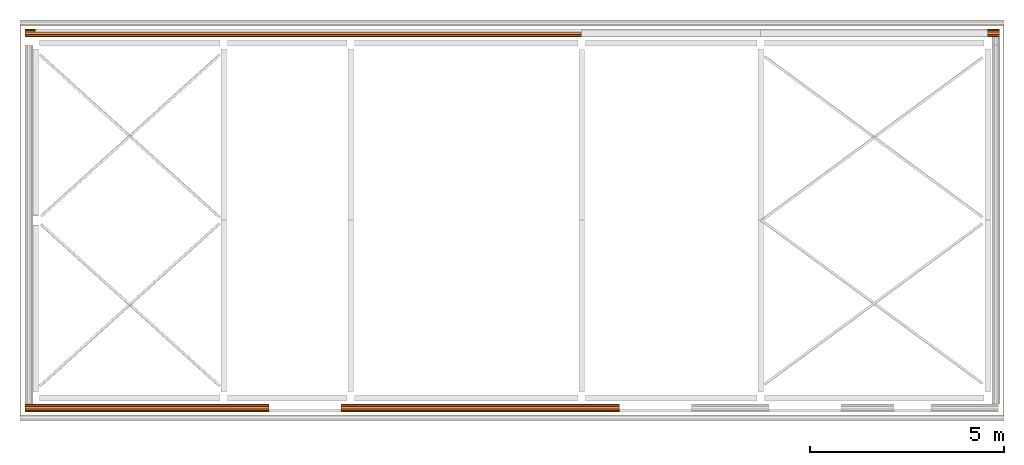
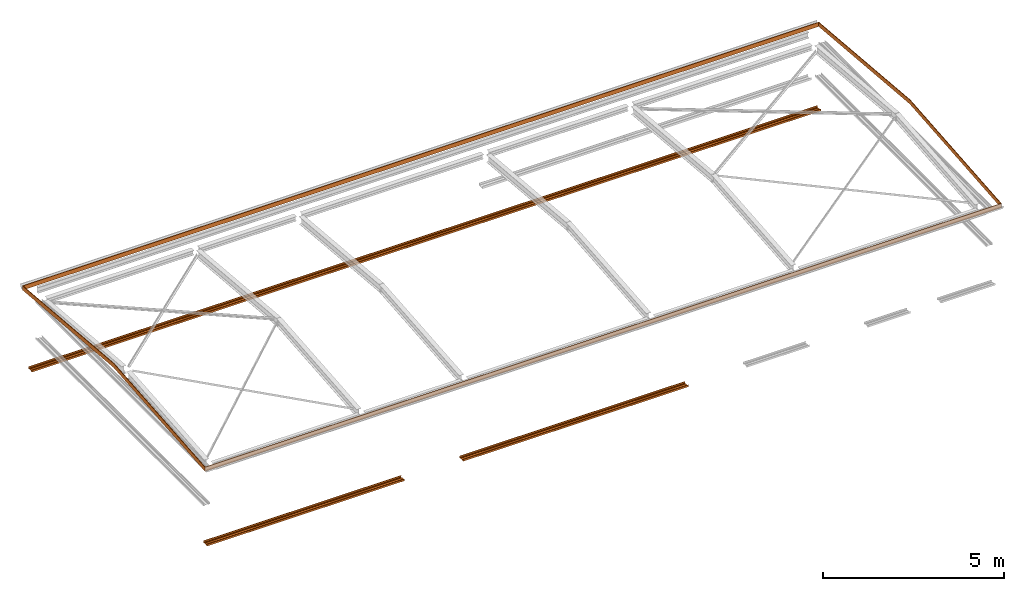
# One storey, part 6 of 8: 4 proxies.
"""IFC2X3 building model written with IfcOpenShell, lengths in millimetres."""

from ifc_helpers import new_model, entity, si_unit, converted_unit, money_unit, direction, frame, origin_with_axes, place, context, subcontext, project, spatial, faceted_brep, material, type_object, element, save


model = new_model("IFC2X3")

# Units and contexts
model_context = context("Model", 3, precision=1e-05, world=origin_with_axes(), true_north=direction((0.0, 1.0)))
body_context = subcontext(model_context, "Body", "Model", "MODEL_VIEW")
ifc_project = project(units=[si_unit("LENGTHUNIT", "METRE", prefix="MILLI"), si_unit("AREAUNIT", "SQUARE_METRE"), si_unit("VOLUMEUNIT", "CUBIC_METRE"), converted_unit("PLANEANGLEUNIT", "DEGREE", entity("IfcPlaneAngleMeasure", 0.0174532925199), si_unit("PLANEANGLEUNIT", "RADIAN"), dimensions=[0, 0, 0, 0, 0, 0, 0]), si_unit("SOLIDANGLEUNIT", "STERADIAN"), money_unit("USD"), converted_unit("TIMEUNIT", "Year", entity("IfcTimeMeasure", 31556926.0), si_unit("TIMEUNIT", "SECOND"), dimensions=[0, 0, 0, 0, 0, 0, 0]), si_unit("MASSUNIT", "GRAM"), si_unit("THERMODYNAMICTEMPERATUREUNIT", "DEGREE_CELSIUS"), si_unit("LUMINOUSINTENSITYUNIT", "LUMEN")], contexts=[model_context])

# Site, building, storey
site_placement = place(None, origin_with_axes())
site = spatial("IfcSite", under=ifc_project, at=site_placement, CompositionType="ELEMENT")
building_placement = place(site_placement, origin_with_axes())
building = spatial("IfcBuilding", under=site, at=building_placement, CompositionType="ELEMENT")
storey_placement = place(building_placement, frame((0.0, 0.0, 74215.0), z_axis=(0.0, 0.0, 1.0), x_axis=(1.0, 0.0, 0.0)))
storey = spatial("IfcBuildingStorey", under=building, at=storey_placement, CompositionType="ELEMENT", Elevation=74215.0)

# Proxies
ifc_material_1 = material(Name="IFC Building Material")
building_element_proxy_type_1 = type_object("IfcBuildingElementProxyType", Name="Model Element 499", PredefinedType="NOTDEFINED")
proxy_1_placement = place(storey_placement, frame((-8525.22088657, -1461.32006319, 111.536956869), z_axis=(0.0, 0.0, 1.0), x_axis=(1.0, 0.0, 0.0)))
element("IfcBuildingElementProxy", 1, at=proxy_1_placement, inside=storey, type_object=building_element_proxy_type_1, material=ifc_material_1, Name="Fascia:Standard", ObjectType="Fascia:Standard", context=body_context, shape_type="Brep", body=[
    faceted_brep([(25333.2504249, 10058.5999698, 140.0), (25352.2504249, 10077.5999698, 140.0), (0.0, 10077.5999698, 140.0), (19.0, 10058.5999698, 140.0), (25352.2504249, 10058.5999698, 140.0), (25352.2504249, 10077.5999698, 0.0), (0.0, 10077.5999698, 0.0), (0.0, 10058.5999698, 140.0), (25333.2504249, 10058.5999698, 0.0), (19.0, 10058.5999698, 0.0), (25333.2504249, 5038.79998489, 579.175591845), (25352.2504249, 5038.79998489, 579.175591845), (25352.2504249, 10052.4874378, 0.0), (0.0, 10052.4874378, 0.0), (0.0, 5038.79998489, 579.175591845), (19.0, 5038.79998489, 579.175591845), (25333.2504249, 10052.4874378, 0.0), (19.0, 10052.4874378, 0.0), (25333.2504249, 19.0, 140.0), (25352.2504249, 19.0, 140.0), (25352.2504249, 5038.79998489, 438.640814589), (25333.2504249, 5038.79998489, 438.640814589), (0.0, 5038.79998489, 438.640814589), (0.0, 19.0, 140.0), (19.0, 19.0, 140.0), (19.0, 5038.79998489, 438.640814589), (25352.2504249, 0.0, 140.0), (25352.2504249, 25.1125320072, 0.0), (25333.2504249, 25.1125320072, 0.0), (0.0, 25.1125320072, 0.0), (0.0, 0.0, 140.0), (19.0, 25.1125320072, 0.0), (25352.2504249, 0.0, 0.0), (25333.2504249, 19.0, 0.0), (0.0, 0.0, 0.0), (19.0, 19.0, 0.0)], [[[0, 1, 2, 3]], [[0, 4, 1]], [[1, 5, 6, 2]], [[3, 2, 7]], [[8, 0, 3, 9]], [[10, 11, 4, 0]], [[4, 12, 5, 1]], [[5, 8, 9, 6]], [[2, 6, 13, 7]], [[3, 7, 14, 15]], [[16, 0, 8]], [[9, 3, 17]], [[18, 19, 11, 10]], [[11, 20, 12, 4]], [[21, 10, 0, 16]], [[12, 16, 8, 5]], [[6, 9, 17, 13]], [[7, 13, 22, 14]], [[15, 14, 23, 24]], [[17, 3, 15, 25]], [[18, 26, 19]], [[19, 27, 20, 11]], [[28, 18, 10, 21]], [[20, 21, 16, 12]], [[13, 17, 25, 22]], [[14, 22, 29, 23]], [[24, 23, 30]], [[25, 15, 24, 31]], [[24, 30, 26, 18]], [[26, 32, 27, 19]], [[27, 28, 21, 20]], [[33, 18, 28]], [[22, 25, 31, 29]], [[23, 29, 34, 30]], [[31, 24, 35]], [[30, 34, 32, 26]], [[35, 24, 18, 33]], [[32, 33, 28, 27]], [[29, 31, 35, 34]], [[34, 35, 33, 32]]]),
])
ifc_material_2 = material(Name="Metal - Steel - Light Gauge")
building_element_proxy_type_2 = type_object("IfcBuildingElementProxyType", Name="M", PredefinedType="USERDEFINED")
proxy_2_placement = place(storey_placement, frame((3315.12953869, -1249.82006319, -2515.0), z_axis=(0.0, 0.0, 1.0), x_axis=(1.0, 0.0, 0.0)))
element("IfcBuildingElementProxy", 2, at=proxy_2_placement, inside=storey, type_object=building_element_proxy_type_2, material=ifc_material_2, Name="Light Gauge-Kingspan Rails:M", ObjectType="M", context=body_context, shape_type="Brep", body=[
    faceted_brep([(-3564.0, 70.5, 0.0), (-3564.0, 99.3, 0.0), (3605.76095051, 99.3, 0.0), (3605.76095051, 70.5, 0.0), (-3564.0, 32.5, 20.0), (-3564.0, -32.5, 20.0), (-3564.0, -70.5, 0.0), (-3564.0, -99.3, 0.0), (-3564.0, -100.524586984, 0.24358549596), (-3564.0, -101.5627417, 0.9372583002), (-3564.0, -102.256414504, 1.97541301643), (-3564.0, -102.5, 3.2), (-3564.0, -102.5, 61.8), (-3564.0, -102.256414504, 63.0245869836), (-3564.0, -101.5627417, 64.0627416998), (-3564.0, -100.524586984, 64.756414504), (-3564.0, -99.3, 65.0), (-3564.0, -91.7, 65.0), (-3564.0, -90.4754130164, 64.756414504), (-3564.0, -89.4372583002, 64.0627416998), (-3564.0, -88.743585496, 63.0245869836), (-3564.0, -88.5, 61.8), (-3564.0, -88.5, 53.0), (-3564.0, -90.1, 53.0), (-3564.0, -90.1, 61.8), (-3564.0, -90.221792748, 62.4122934918), (-3564.0, -90.5686291501, 62.9313708499), (-3564.0, -91.0877065082, 63.278207252), (-3564.0, -91.7, 63.4), (-3564.0, -99.3, 63.4), (-3564.0, -99.9122934918, 63.278207252), (-3564.0, -100.43137085, 62.9313708499), (-3564.0, -100.778207252, 62.4122934918), (-3564.0, -100.9, 61.8), (-3564.0, -100.9, 3.2), (-3564.0, -100.778207252, 2.58770650822), (-3564.0, -100.43137085, 2.0686291501), (-3564.0, -99.9122934918, 1.72179274798), (-3564.0, -99.3, 1.6), (-3564.0, -70.8953456886, 1.6), (-3564.0, -32.8953456886, 21.6), (-3564.0, 32.8953456886, 21.6), (-3564.0, 70.8953456886, 1.6), (-3564.0, 99.3, 1.6), (-3564.0, 99.9122934918, 1.72179274798), (-3564.0, 100.43137085, 2.0686291501), (-3564.0, 100.778207252, 2.58770650822), (-3564.0, 100.9, 3.2), (-3564.0, 100.9, 61.8), (-3564.0, 100.778207252, 62.4122934918), (-3564.0, 100.43137085, 62.9313708499), (-3564.0, 99.9122934918, 63.278207252), (-3564.0, 99.3, 63.4), (-3564.0, 91.7, 63.4), (-3564.0, 91.0877065082, 63.278207252), (-3564.0, 90.5686291501, 62.9313708499), (-3564.0, 90.221792748, 62.4122934918), (-3564.0, 90.1, 61.8), (-3564.0, 90.1, 53.0), (-3564.0, 88.5, 53.0), (-3564.0, 88.5, 61.8), (-3564.0, 88.743585496, 63.0245869836), (-3564.0, 89.4372583002, 64.0627416998), (-3564.0, 90.4754130164, 64.756414504), (-3564.0, 91.7, 65.0), (-3564.0, 99.3, 65.0), (-3564.0, 100.524586984, 64.756414504), (-3564.0, 101.5627417, 64.0627416998), (-3564.0, 102.256414504, 63.0245869836), (-3564.0, 102.5, 61.8), (-3564.0, 102.5, 3.2), (-3564.0, 102.256414504, 1.97541301643), (-3564.0, 101.5627417, 0.9372583002), (-3564.0, 100.524586984, 0.24358549596), (3605.76095051, 100.524586984, 0.24358549596), (3605.76095051, 101.5627417, 0.9372583002), (3605.76095051, 102.256414504, 1.97541301643), (3605.76095051, 102.5, 3.2), (3605.76095051, 102.5, 61.8), (3605.76095051, 102.256414504, 63.0245869836), (3605.76095051, 101.5627417, 64.0627416998), (3605.76095051, 100.524586984, 64.756414504), (3605.76095051, 99.3, 65.0), (3605.76095051, 91.7, 65.0), (3605.76095051, 90.4754130164, 64.756414504), (3605.76095051, 89.4372583002, 64.0627416998), (3605.76095051, 88.743585496, 63.0245869836), (3605.76095051, 88.5, 61.8), (3605.76095051, 88.5, 53.0), (3605.76095051, 90.1, 53.0), (3605.76095051, 90.1, 61.8), (3605.76095051, 90.221792748, 62.4122934918), (3605.76095051, 90.5686291501, 62.9313708499), (3605.76095051, 91.0877065082, 63.278207252), (3605.76095051, 91.7, 63.4), (3605.76095051, 99.3, 63.4), (3605.76095051, 99.9122934918, 63.278207252), (3605.76095051, 100.43137085, 62.9313708499), (3605.76095051, 100.778207252, 62.4122934918), (3605.76095051, 100.9, 61.8), (3605.76095051, 100.9, 3.2), (3605.76095051, 100.778207252, 2.58770650822), (3605.76095051, 100.43137085, 2.0686291501), (3605.76095051, 99.9122934918, 1.72179274798), (3605.76095051, 99.3, 1.6), (3605.76095051, 70.8953456886, 1.6), (3605.76095051, 32.8953456886, 21.6), (3605.76095051, -32.8953456886, 21.6), (3605.76095051, -70.8953456886, 1.6), (3605.76095051, -99.3, 1.6), (3605.76095051, -99.9122934918, 1.72179274798), (3605.76095051, -100.43137085, 2.0686291501), (3605.76095051, -100.778207252, 2.58770650822), (3605.76095051, -100.9, 3.2), (3605.76095051, -100.9, 61.8), (3605.76095051, -100.778207252, 62.4122934918), (3605.76095051, -100.43137085, 62.9313708499), (3605.76095051, -99.9122934918, 63.278207252), (3605.76095051, -99.3, 63.4), (3605.76095051, -91.7, 63.4), (3605.76095051, -91.0877065082, 63.278207252), (3605.76095051, -90.5686291501, 62.9313708499), (3605.76095051, -90.221792748, 62.4122934918), (3605.76095051, -90.1, 61.8), (3605.76095051, -90.1, 53.0), (3605.76095051, -88.5, 53.0), (3605.76095051, -88.5, 61.8), (3605.76095051, -88.743585496, 63.0245869836), (3605.76095051, -89.4372583002, 64.0627416998), (3605.76095051, -90.4754130164, 64.756414504), (3605.76095051, -91.7, 65.0), (3605.76095051, -99.3, 65.0), (3605.76095051, -100.524586984, 64.756414504), (3605.76095051, -101.5627417, 64.0627416998), (3605.76095051, -102.256414504, 63.0245869836), (3605.76095051, -102.5, 61.8), (3605.76095051, -102.5, 3.2), (3605.76095051, -102.256414504, 1.97541301643), (3605.76095051, -101.5627417, 0.9372583002), (3605.76095051, -100.524586984, 0.24358549596), (3605.76095051, -99.3, 0.0), (3605.76095051, -70.5, 0.0), (3605.76095051, -32.5, 20.0), (3605.76095051, 32.5, 20.0)], [[[0, 1, 2, 3]], [[0, 4, 5, 6, 7, 8, 9, 10, 11, 12, 13, 14, 15, 16, 17, 18, 19, 20, 21, 22, 23, 24, 25, 26, 27, 28, 29, 30, 31, 32, 33, 34, 35, 36, 37, 38, 39, 40, 41, 42, 43, 44, 45, 46, 47, 48, 49, 50, 51, 52, 53, 54, 55, 56, 57, 58, 59, 60, 61, 62, 63, 64, 65, 66, 67, 68, 69, 70, 71, 72, 73, 1]], [[1, 73, 74, 2]], [[3, 2, 74, 75, 76, 77, 78, 79, 80, 81, 82, 83, 84, 85, 86, 87, 88, 89, 90, 91, 92, 93, 94, 95, 96, 97, 98, 99, 100, 101, 102, 103, 104, 105, 106, 107, 108, 109, 110, 111, 112, 113, 114, 115, 116, 117, 118, 119, 120, 121, 122, 123, 124, 125, 126, 127, 128, 129, 130, 131, 132, 133, 134, 135, 136, 137, 138, 139, 140, 141, 142, 143]], [[4, 0, 3, 143]], [[5, 4, 143, 142]], [[6, 5, 142, 141]], [[7, 6, 141, 140]], [[8, 7, 140, 139]], [[9, 8, 139, 138]], [[10, 9, 138, 137]], [[11, 10, 137, 136]], [[12, 11, 136, 135]], [[13, 12, 135, 134]], [[14, 13, 134, 133]], [[15, 14, 133, 132]], [[16, 15, 132, 131]], [[17, 16, 131, 130]], [[18, 17, 130, 129]], [[19, 18, 129, 128]], [[20, 19, 128, 127]], [[21, 20, 127, 126]], [[22, 21, 126, 125]], [[23, 22, 125, 124]], [[24, 23, 124, 123]], [[25, 24, 123, 122]], [[26, 25, 122, 121]], [[27, 26, 121, 120]], [[28, 27, 120, 119]], [[29, 28, 119, 118]], [[30, 29, 118, 117]], [[31, 30, 117, 116]], [[32, 31, 116, 115]], [[33, 32, 115, 114]], [[34, 33, 114, 113]], [[35, 34, 113, 112]], [[36, 35, 112, 111]], [[37, 36, 111, 110]], [[38, 37, 110, 109]], [[39, 38, 109, 108]], [[40, 39, 108, 107]], [[41, 40, 107, 106]], [[42, 41, 106, 105]], [[43, 42, 105, 104]], [[44, 43, 104, 103]], [[45, 44, 103, 102]], [[46, 45, 102, 101]], [[47, 46, 101, 100]], [[48, 47, 100, 99]], [[49, 48, 99, 98]], [[50, 49, 98, 97]], [[51, 50, 97, 96]], [[52, 51, 96, 95]], [[53, 52, 95, 94]], [[54, 53, 94, 93]], [[55, 54, 93, 92]], [[56, 55, 92, 91]], [[57, 56, 91, 90]], [[58, 57, 90, 89]], [[59, 58, 89, 88]], [[60, 59, 88, 87]], [[61, 60, 87, 86]], [[62, 61, 86, 85]], [[63, 62, 85, 84]], [[64, 63, 84, 83]], [[65, 64, 83, 82]], [[66, 65, 82, 81]], [[67, 66, 81, 80]], [[68, 67, 80, 79]], [[69, 68, 79, 78]], [[70, 69, 78, 77]], [[71, 70, 77, 76]], [[72, 71, 76, 75]], [[73, 72, 75, 74]]]),
])
ifc_material_3 = material(Name="Metal - Steel 43-275")
building_element_proxy_type_3 = type_object("IfcBuildingElementProxyType", Name="M", PredefinedType="USERDEFINED")
proxy_3_placement = place(storey_placement, frame((-4689.87046131, -1249.82006319, -2515.0), z_axis=(0.0, 0.0, 1.0), x_axis=(1.0, 0.0, 0.0)))
element("IfcBuildingElementProxy", 3, at=proxy_3_placement, inside=storey, type_object=building_element_proxy_type_3, material=ifc_material_3, Name="Light Gauge-Kingspan Rails:M", ObjectType="M", context=body_context, shape_type="Brep", body=[
    faceted_brep([(-3708.0500015, 70.5, 0.0), (-3708.0500015, 99.3, 0.0), (2580.64956947, 99.3, 0.0), (2580.64956947, 70.5, 0.0), (-3708.0500015, 32.5, 20.0), (-3708.0500015, -32.5, 20.0), (-3708.0500015, -70.5, 0.0), (-3708.0500015, -99.3, 0.0), (-3708.0500015, -100.524586984, 0.24358549596), (-3708.0500015, -101.5627417, 0.9372583002), (-3708.0500015, -102.256414504, 1.97541301643), (-3708.0500015, -102.5, 3.2), (-3708.0500015, -102.5, 61.8), (-3708.0500015, -102.256414504, 63.0245869836), (-3708.0500015, -101.5627417, 64.0627416998), (-3708.0500015, -100.524586984, 64.756414504), (-3708.0500015, -99.3, 65.0), (-3708.0500015, -91.7, 65.0), (-3708.0500015, -90.4754130164, 64.756414504), (-3708.0500015, -89.4372583002, 64.0627416998), (-3708.0500015, -88.743585496, 63.0245869836), (-3708.0500015, -88.5, 61.8), (-3708.0500015, -88.5, 53.0), (-3708.0500015, -90.1, 53.0), (-3708.0500015, -90.1, 61.8), (-3708.0500015, -90.221792748, 62.4122934918), (-3708.0500015, -90.5686291501, 62.9313708499), (-3708.0500015, -91.0877065082, 63.278207252), (-3708.0500015, -91.7, 63.4), (-3708.0500015, -99.3, 63.4), (-3708.0500015, -99.9122934918, 63.278207252), (-3708.0500015, -100.43137085, 62.9313708499), (-3708.0500015, -100.778207252, 62.4122934918), (-3708.0500015, -100.9, 61.8), (-3708.0500015, -100.9, 3.2), (-3708.0500015, -100.778207252, 2.58770650822), (-3708.0500015, -100.43137085, 2.0686291501), (-3708.0500015, -99.9122934918, 1.72179274798), (-3708.0500015, -99.3, 1.6), (-3708.0500015, -70.8953456886, 1.6), (-3708.0500015, -32.8953456886, 21.6), (-3708.0500015, 32.8953456886, 21.6), (-3708.0500015, 70.8953456886, 1.6), (-3708.0500015, 99.3, 1.6), (-3708.0500015, 99.9122934918, 1.72179274798), (-3708.0500015, 100.43137085, 2.0686291501), (-3708.0500015, 100.778207252, 2.58770650822), (-3708.0500015, 100.9, 3.2), (-3708.0500015, 100.9, 61.8), (-3708.0500015, 100.778207252, 62.4122934918), (-3708.0500015, 100.43137085, 62.9313708499), (-3708.0500015, 99.9122934918, 63.278207252), (-3708.0500015, 99.3, 63.4), (-3708.0500015, 91.7, 63.4), (-3708.0500015, 91.0877065082, 63.278207252), (-3708.0500015, 90.5686291501, 62.9313708499), (-3708.0500015, 90.221792748, 62.4122934918), (-3708.0500015, 90.1, 61.8), (-3708.0500015, 90.1, 53.0), (-3708.0500015, 88.5, 53.0), (-3708.0500015, 88.5, 61.8), (-3708.0500015, 88.743585496, 63.0245869836), (-3708.0500015, 89.4372583002, 64.0627416998), (-3708.0500015, 90.4754130164, 64.756414504), (-3708.0500015, 91.7, 65.0), (-3708.0500015, 99.3, 65.0), (-3708.0500015, 100.524586984, 64.756414504), (-3708.0500015, 101.5627417, 64.0627416998), (-3708.0500015, 102.256414504, 63.0245869836), (-3708.0500015, 102.5, 61.8), (-3708.0500015, 102.5, 3.2), (-3708.0500015, 102.256414504, 1.97541301643), (-3708.0500015, 101.5627417, 0.9372583002), (-3708.0500015, 100.524586984, 0.24358549596), (2580.64956947, 100.524586984, 0.24358549596), (2580.64956947, 101.5627417, 0.9372583002), (2580.64956947, 102.256414504, 1.97541301643), (2580.64956947, 102.5, 3.2), (2580.64956947, 102.5, 61.8), (2580.64956947, 102.256414504, 63.0245869836), (2580.64956947, 101.5627417, 64.0627416998), (2580.64956947, 100.524586984, 64.756414504), (2580.64956947, 99.3, 65.0), (2580.64956947, 91.7, 65.0), (2580.64956947, 90.4754130164, 64.756414504), (2580.64956947, 89.4372583002, 64.0627416998), (2580.64956947, 88.743585496, 63.0245869836), (2580.64956947, 88.5, 61.8), (2580.64956947, 88.5, 53.0), (2580.64956947, 90.1, 53.0), (2580.64956947, 90.1, 61.8), (2580.64956947, 90.221792748, 62.4122934918), (2580.64956947, 90.5686291501, 62.9313708499), (2580.64956947, 91.0877065082, 63.278207252), (2580.64956947, 91.7, 63.4), (2580.64956947, 99.3, 63.4), (2580.64956947, 99.9122934918, 63.278207252), (2580.64956947, 100.43137085, 62.9313708499), (2580.64956947, 100.778207252, 62.4122934918), (2580.64956947, 100.9, 61.8), (2580.64956947, 100.9, 3.2), (2580.64956947, 100.778207252, 2.58770650822), (2580.64956947, 100.43137085, 2.0686291501), (2580.64956947, 99.9122934918, 1.72179274798), (2580.64956947, 99.3, 1.6), (2580.64956947, 70.8953456886, 1.6), (2580.64956947, 32.8953456886, 21.6), (2580.64956947, -32.8953456886, 21.6), (2580.64956947, -70.8953456886, 1.6), (2580.64956947, -99.3, 1.6), (2580.64956947, -99.9122934918, 1.72179274798), (2580.64956947, -100.43137085, 2.0686291501), (2580.64956947, -100.778207252, 2.58770650822), (2580.64956947, -100.9, 3.2), (2580.64956947, -100.9, 61.8), (2580.64956947, -100.778207252, 62.4122934918), (2580.64956947, -100.43137085, 62.9313708499), (2580.64956947, -99.9122934918, 63.278207252), (2580.64956947, -99.3, 63.4), (2580.64956947, -91.7, 63.4), (2580.64956947, -91.0877065082, 63.278207252), (2580.64956947, -90.5686291501, 62.9313708499), (2580.64956947, -90.221792748, 62.4122934918), (2580.64956947, -90.1, 61.8), (2580.64956947, -90.1, 53.0), (2580.64956947, -88.5, 53.0), (2580.64956947, -88.5, 61.8), (2580.64956947, -88.743585496, 63.0245869836), (2580.64956947, -89.4372583002, 64.0627416998), (2580.64956947, -90.4754130164, 64.756414504), (2580.64956947, -91.7, 65.0), (2580.64956947, -99.3, 65.0), (2580.64956947, -100.524586984, 64.756414504), (2580.64956947, -101.5627417, 64.0627416998), (2580.64956947, -102.256414504, 63.0245869836), (2580.64956947, -102.5, 61.8), (2580.64956947, -102.5, 3.2), (2580.64956947, -102.256414504, 1.97541301643), (2580.64956947, -101.5627417, 0.9372583002), (2580.64956947, -100.524586984, 0.24358549596), (2580.64956947, -99.3, 0.0), (2580.64956947, -70.5, 0.0), (2580.64956947, -32.5, 20.0), (2580.64956947, 32.5, 20.0)], [[[0, 1, 2, 3]], [[0, 4, 5, 6, 7, 8, 9, 10, 11, 12, 13, 14, 15, 16, 17, 18, 19, 20, 21, 22, 23, 24, 25, 26, 27, 28, 29, 30, 31, 32, 33, 34, 35, 36, 37, 38, 39, 40, 41, 42, 43, 44, 45, 46, 47, 48, 49, 50, 51, 52, 53, 54, 55, 56, 57, 58, 59, 60, 61, 62, 63, 64, 65, 66, 67, 68, 69, 70, 71, 72, 73, 1]], [[1, 73, 74, 2]], [[3, 2, 74, 75, 76, 77, 78, 79, 80, 81, 82, 83, 84, 85, 86, 87, 88, 89, 90, 91, 92, 93, 94, 95, 96, 97, 98, 99, 100, 101, 102, 103, 104, 105, 106, 107, 108, 109, 110, 111, 112, 113, 114, 115, 116, 117, 118, 119, 120, 121, 122, 123, 124, 125, 126, 127, 128, 129, 130, 131, 132, 133, 134, 135, 136, 137, 138, 139, 140, 141, 142, 143]], [[4, 0, 3, 143]], [[5, 4, 143, 142]], [[6, 5, 142, 141]], [[7, 6, 141, 140]], [[8, 7, 140, 139]], [[9, 8, 139, 138]], [[10, 9, 138, 137]], [[11, 10, 137, 136]], [[12, 11, 136, 135]], [[13, 12, 135, 134]], [[14, 13, 134, 133]], [[15, 14, 133, 132]], [[16, 15, 132, 131]], [[17, 16, 131, 130]], [[18, 17, 130, 129]], [[19, 18, 129, 128]], [[20, 19, 128, 127]], [[21, 20, 127, 126]], [[22, 21, 126, 125]], [[23, 22, 125, 124]], [[24, 23, 124, 123]], [[25, 24, 123, 122]], [[26, 25, 122, 121]], [[27, 26, 121, 120]], [[28, 27, 120, 119]], [[29, 28, 119, 118]], [[30, 29, 118, 117]], [[31, 30, 117, 116]], [[32, 31, 116, 115]], [[33, 32, 115, 114]], [[34, 33, 114, 113]], [[35, 34, 113, 112]], [[36, 35, 112, 111]], [[37, 36, 111, 110]], [[38, 37, 110, 109]], [[39, 38, 109, 108]], [[40, 39, 108, 107]], [[41, 40, 107, 106]], [[42, 41, 106, 105]], [[43, 42, 105, 104]], [[44, 43, 104, 103]], [[45, 44, 103, 102]], [[46, 45, 102, 101]], [[47, 46, 101, 100]], [[48, 47, 100, 99]], [[49, 48, 99, 98]], [[50, 49, 98, 97]], [[51, 50, 97, 96]], [[52, 51, 96, 95]], [[53, 52, 95, 94]], [[54, 53, 94, 93]], [[55, 54, 93, 92]], [[56, 55, 92, 91]], [[57, 56, 91, 90]], [[58, 57, 90, 89]], [[59, 58, 89, 88]], [[60, 59, 88, 87]], [[61, 60, 87, 86]], [[62, 61, 86, 85]], [[63, 62, 85, 84]], [[64, 63, 84, 83]], [[65, 64, 83, 82]], [[66, 65, 82, 81]], [[67, 66, 81, 80]], [[68, 67, 80, 79]], [[69, 68, 79, 78]], [[70, 69, 78, 77]], [[71, 70, 77, 76]], [[72, 71, 76, 75]], [[73, 72, 75, 74]]]),
])
building_element_proxy_type_4 = type_object("IfcBuildingElementProxyType", Name="M", PredefinedType="USERDEFINED")
proxy_4_placement = place(storey_placement, frame((4247.8295385, 8404.77990658, -2515.0), z_axis=(0.0, 0.0, 1.0), x_axis=(1.0, 0.0, 0.0)))
element("IfcBuildingElementProxy", 4, at=proxy_4_placement, inside=storey, type_object=building_element_proxy_type_4, material=ifc_material_3, Name="Light Gauge-Kingspan Rails:M", ObjectType="M", context=body_context, shape_type="Brep", body=[
    faceted_brep([(12467.5, -70.5, 0.0), (12467.5, -99.3, 0.0), (-12645.5500015, -99.3, 0.0), (-12645.5500015, -70.5, 0.0), (12467.5, -32.5, 20.0), (12467.5, 32.5, 20.0), (12467.5, 70.5, 0.0), (12467.5, 99.3, 0.0), (12467.5, 100.524586984, 0.24358549596), (12467.5, 101.5627417, 0.9372583002), (12467.5, 102.256414504, 1.97541301643), (12467.5, 102.5, 3.2), (12467.5, 102.5, 61.8), (12467.5, 102.256414504, 63.0245869836), (12467.5, 101.5627417, 64.0627416998), (12467.5, 100.524586984, 64.756414504), (12467.5, 99.3, 65.0), (12467.5, 91.7, 65.0), (12467.5, 90.4754130164, 64.756414504), (12467.5, 89.4372583002, 64.0627416998), (12467.5, 88.743585496, 63.0245869836), (12467.5, 88.5, 61.8), (12467.5, 88.5, 53.0), (12467.5, 90.1, 53.0), (12467.5, 90.1, 61.8), (12467.5, 90.221792748, 62.4122934918), (12467.5, 90.5686291501, 62.9313708499), (12467.5, 91.0877065082, 63.278207252), (12467.5, 91.7, 63.4), (12467.5, 99.3, 63.4), (12467.5, 99.9122934918, 63.278207252), (12467.5, 100.43137085, 62.9313708499), (12467.5, 100.778207252, 62.4122934918), (12467.5, 100.9, 61.8), (12467.5, 100.9, 3.19999999999), (12467.5, 100.778207252, 2.58770650821), (12467.5, 100.43137085, 2.0686291501), (12467.5, 99.9122934918, 1.72179274798), (12467.5, 99.3, 1.6), (12467.5, 70.8953456886, 1.6), (12467.5, 32.8953456886, 21.6), (12467.5, -32.8953456886, 21.6), (12467.5, -70.8953456886, 1.6), (12467.5, -99.3, 1.6), (12467.5, -99.9122934918, 1.72179274798), (12467.5, -100.43137085, 2.0686291501), (12467.5, -100.778207252, 2.58770650821), (12467.5, -100.9, 3.19999999999), (12467.5, -100.9, 61.8), (12467.5, -100.778207252, 62.4122934918), (12467.5, -100.43137085, 62.9313708499), (12467.5, -99.9122934918, 63.278207252), (12467.5, -99.3, 63.4), (12467.5, -91.7, 63.4), (12467.5, -91.0877065082, 63.278207252), (12467.5, -90.5686291501, 62.9313708499), (12467.5, -90.221792748, 62.4122934918), (12467.5, -90.1, 61.8), (12467.5, -90.1, 53.0), (12467.5, -88.5, 53.0), (12467.5, -88.5, 61.8), (12467.5, -88.743585496, 63.0245869836), (12467.5, -89.4372583002, 64.0627416998), (12467.5, -90.4754130164, 64.756414504), (12467.5, -91.7, 65.0), (12467.5, -99.3, 65.0), (12467.5, -100.524586984, 64.756414504), (12467.5, -101.5627417, 64.0627416998), (12467.5, -102.256414504, 63.0245869836), (12467.5, -102.5, 61.8), (12467.5, -102.5, 3.19999999999), (12467.5, -102.256414504, 1.97541301643), (12467.5, -101.5627417, 0.9372583002), (12467.5, -100.524586984, 0.24358549596), (-12645.5500015, -100.524586984, 0.24358549596), (-12645.5500015, -101.5627417, 0.9372583002), (-12645.5500015, -102.256414504, 1.97541301643), (-12645.5500015, -102.5, 3.19999999999), (-12645.5500015, -102.5, 61.8), (-12645.5500015, -102.256414504, 63.0245869836), (-12645.5500015, -101.5627417, 64.0627416998), (-12645.5500015, -100.524586984, 64.756414504), (-12645.5500015, -99.3, 65.0), (-12645.5500015, -91.7, 65.0), (-12645.5500015, -90.4754130164, 64.756414504), (-12645.5500015, -89.4372583002, 64.0627416998), (-12645.5500015, -88.743585496, 63.0245869836), (-12645.5500015, -88.5, 61.8), (-12645.5500015, -88.5, 53.0), (-12645.5500015, -90.1, 53.0), (-12645.5500015, -90.1, 61.8), (-12645.5500015, -90.221792748, 62.4122934918), (-12645.5500015, -90.5686291501, 62.9313708499), (-12645.5500015, -91.0877065082, 63.278207252), (-12645.5500015, -91.7, 63.4), (-12645.5500015, -99.3, 63.4), (-12645.5500015, -99.9122934918, 63.278207252), (-12645.5500015, -100.43137085, 62.9313708499), (-12645.5500015, -100.778207252, 62.4122934918), (-12645.5500015, -100.9, 61.8), (-12645.5500015, -100.9, 3.19999999999), (-12645.5500015, -100.778207252, 2.58770650821), (-12645.5500015, -100.43137085, 2.0686291501), (-12645.5500015, -99.9122934918, 1.72179274798), (-12645.5500015, -99.3, 1.6), (-12645.5500015, -70.8953456886, 1.6), (-12645.5500015, -32.8953456886, 21.6), (-12645.5500015, 32.8953456886, 21.6), (-12645.5500015, 70.8953456886, 1.6), (-12645.5500015, 99.3, 1.6), (-12645.5500015, 99.9122934918, 1.72179274798), (-12645.5500015, 100.43137085, 2.0686291501), (-12645.5500015, 100.778207252, 2.58770650821), (-12645.5500015, 100.9, 3.19999999999), (-12645.5500015, 100.9, 61.8), (-12645.5500015, 100.778207252, 62.4122934918), (-12645.5500015, 100.43137085, 62.9313708499), (-12645.5500015, 99.9122934918, 63.278207252), (-12645.5500015, 99.3, 63.4), (-12645.5500015, 91.7, 63.4), (-12645.5500015, 91.0877065082, 63.278207252), (-12645.5500015, 90.5686291501, 62.9313708499), (-12645.5500015, 90.221792748, 62.4122934918), (-12645.5500015, 90.1, 61.8), (-12645.5500015, 90.1, 53.0), (-12645.5500015, 88.5, 53.0), (-12645.5500015, 88.5, 61.8), (-12645.5500015, 88.743585496, 63.0245869836), (-12645.5500015, 89.4372583002, 64.0627416998), (-12645.5500015, 90.4754130164, 64.756414504), (-12645.5500015, 91.7, 65.0), (-12645.5500015, 99.3, 65.0), (-12645.5500015, 100.524586984, 64.756414504), (-12645.5500015, 101.5627417, 64.0627416998), (-12645.5500015, 102.256414504, 63.0245869836), (-12645.5500015, 102.5, 61.8), (-12645.5500015, 102.5, 3.2), (-12645.5500015, 102.256414504, 1.97541301643), (-12645.5500015, 101.5627417, 0.9372583002), (-12645.5500015, 100.524586984, 0.24358549596), (-12645.5500015, 99.3, 0.0), (-12645.5500015, 70.5, 0.0), (-12645.5500015, 32.5, 20.0), (-12645.5500015, -32.5, 20.0)], [[[0, 1, 2, 3]], [[0, 4, 5, 6, 7, 8, 9, 10, 11, 12, 13, 14, 15, 16, 17, 18, 19, 20, 21, 22, 23, 24, 25, 26, 27, 28, 29, 30, 31, 32, 33, 34, 35, 36, 37, 38, 39, 40, 41, 42, 43, 44, 45, 46, 47, 48, 49, 50, 51, 52, 53, 54, 55, 56, 57, 58, 59, 60, 61, 62, 63, 64, 65, 66, 67, 68, 69, 70, 71, 72, 73, 1]], [[1, 73, 74, 2]], [[3, 2, 74, 75, 76, 77, 78, 79, 80, 81, 82, 83, 84, 85, 86, 87, 88, 89, 90, 91, 92, 93, 94, 95, 96, 97, 98, 99, 100, 101, 102, 103, 104, 105, 106, 107, 108, 109, 110, 111, 112, 113, 114, 115, 116, 117, 118, 119, 120, 121, 122, 123, 124, 125, 126, 127, 128, 129, 130, 131, 132, 133, 134, 135, 136, 137, 138, 139, 140, 141, 142, 143]], [[4, 0, 3, 143]], [[5, 4, 143, 142]], [[6, 5, 142, 141]], [[7, 6, 141, 140]], [[8, 7, 140, 139]], [[9, 8, 139, 138]], [[10, 9, 138, 137]], [[11, 10, 137, 136]], [[12, 11, 136, 135]], [[13, 12, 135, 134]], [[14, 13, 134, 133]], [[15, 14, 133, 132]], [[16, 15, 132, 131]], [[17, 16, 131, 130]], [[18, 17, 130, 129]], [[19, 18, 129, 128]], [[20, 19, 128, 127]], [[21, 20, 127, 126]], [[22, 21, 126, 125]], [[23, 22, 125, 124]], [[24, 23, 124, 123]], [[25, 24, 123, 122]], [[26, 25, 122, 121]], [[27, 26, 121, 120]], [[28, 27, 120, 119]], [[29, 28, 119, 118]], [[30, 29, 118, 117]], [[31, 30, 117, 116]], [[32, 31, 116, 115]], [[33, 32, 115, 114]], [[34, 33, 114, 113]], [[35, 34, 113, 112]], [[36, 35, 112, 111]], [[37, 36, 111, 110]], [[38, 37, 110, 109]], [[39, 38, 109, 108]], [[40, 39, 108, 107]], [[41, 40, 107, 106]], [[42, 41, 106, 105]], [[43, 42, 105, 104]], [[44, 43, 104, 103]], [[45, 44, 103, 102]], [[46, 45, 102, 101]], [[47, 46, 101, 100]], [[48, 47, 100, 99]], [[49, 48, 99, 98]], [[50, 49, 98, 97]], [[51, 50, 97, 96]], [[52, 51, 96, 95]], [[53, 52, 95, 94]], [[54, 53, 94, 93]], [[55, 54, 93, 92]], [[56, 55, 92, 91]], [[57, 56, 91, 90]], [[58, 57, 90, 89]], [[59, 58, 89, 88]], [[60, 59, 88, 87]], [[61, 60, 87, 86]], [[62, 61, 86, 85]], [[63, 62, 85, 84]], [[64, 63, 84, 83]], [[65, 64, 83, 82]], [[66, 65, 82, 81]], [[67, 66, 81, 80]], [[68, 67, 80, 79]], [[69, 68, 79, 78]], [[70, 69, 78, 77]], [[71, 70, 77, 76]], [[72, 71, 76, 75]], [[73, 72, 75, 74]]]),
])

save(model, "model.ifc")
